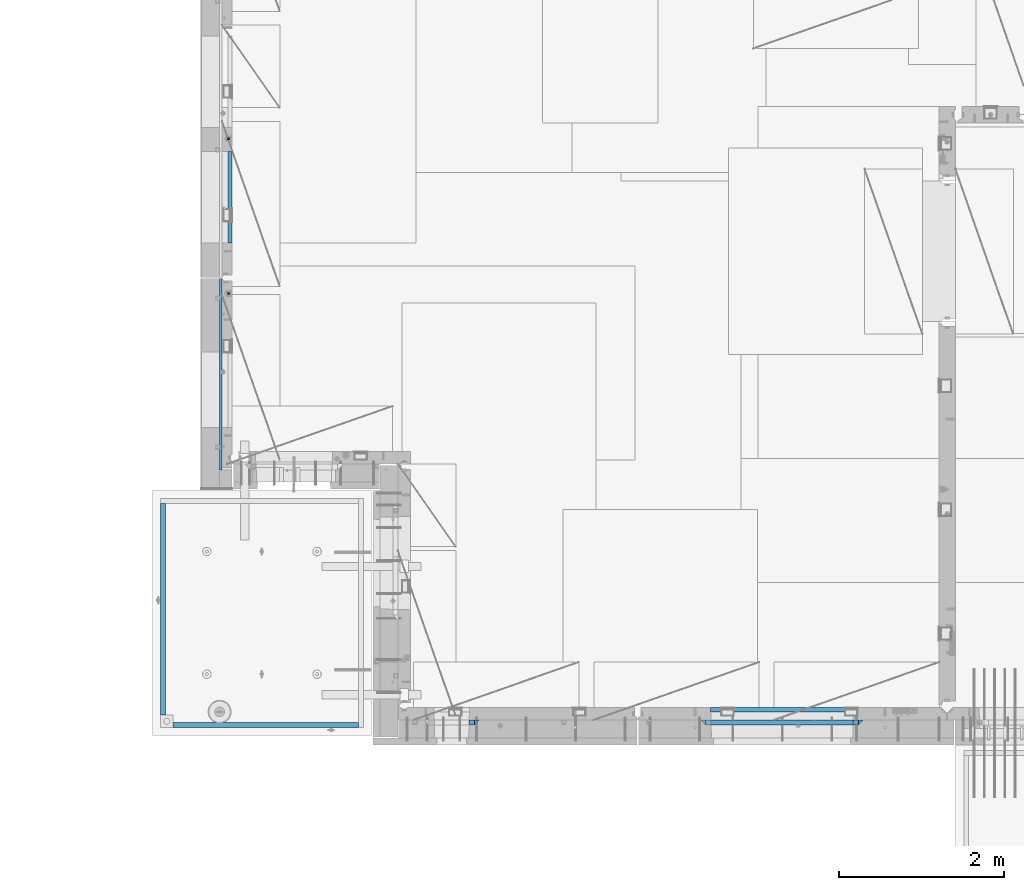
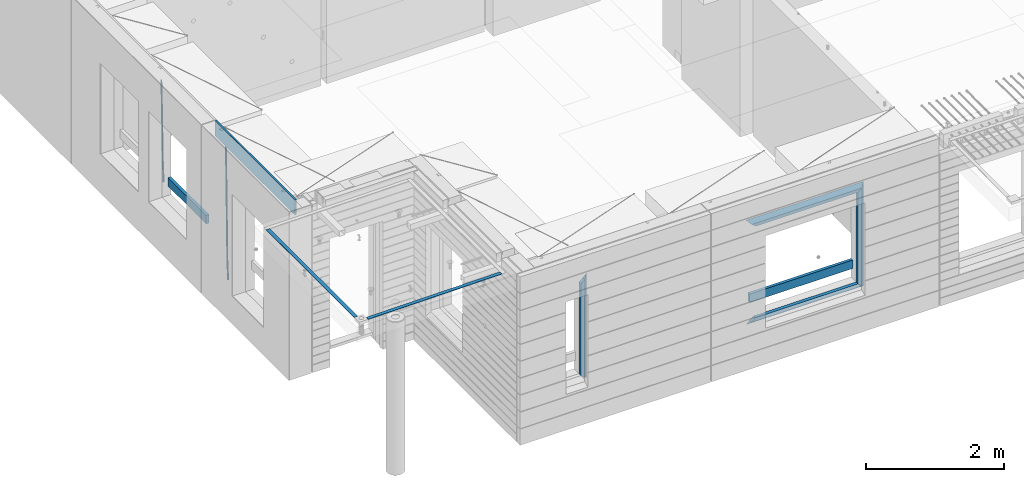
# One storey, part 87 of 341: 15 beams, 5 elements without a shape of their own.
"""IFC2X3 building model written with IfcOpenShell, lengths in millimetres."""

from ifc_helpers import new_model, si_unit, frame, origin_with_axes, place, context, subcontext, project, spatial, faceted_brep, material, type_object, element, aggregate, save


model = new_model("IFC2X3")

# Units and contexts
model_context = context("Model", 3, precision=1e-05, world=origin_with_axes())
body_context = subcontext(model_context, "Body", "Model", "MODEL_VIEW")
ifc_project = project(units=[si_unit("LENGTHUNIT", "METRE", prefix="MILLI"), si_unit("AREAUNIT", "SQUARE_METRE"), si_unit("VOLUMEUNIT", "CUBIC_METRE"), si_unit("MASSUNIT", "GRAM", prefix="KILO"), si_unit("TIMEUNIT", "SECOND"), si_unit("PLANEANGLEUNIT", "RADIAN"), si_unit("SOLIDANGLEUNIT", "STERADIAN"), si_unit("THERMODYNAMICTEMPERATUREUNIT", "DEGREE_CELSIUS"), si_unit("LUMINOUSINTENSITYUNIT", "LUMEN")], contexts=[model_context])

# Site, building, storey
site_placement = place(None, origin_with_axes())
site = spatial("IfcSite", under=ifc_project, at=site_placement, CompositionType="ELEMENT")
building_placement = place(site_placement, origin_with_axes())
building = spatial("IfcBuilding", under=site, at=building_placement, CompositionType="ELEMENT")
storey_placement = place(building_placement, origin_with_axes())
storey = spatial("IfcBuildingStorey", under=building, at=storey_placement, Name="5", CompositionType="ELEMENT", Elevation=0.0)

# Assembly, beam
assembly_1_placement = place(storey_placement, origin_with_axes())
assembly_1 = element("IfcElementAssembly", 1, at=assembly_1_placement, inside=storey, AssemblyPlace="NOTDEFINED", PredefinedType="REINFORCEMENT_UNIT")
ifc_material_1 = material()
beam_type_1 = type_object("IfcBeamType", Name="D20", PredefinedType="NOTDEFINED")
beam_1_placement = place(assembly_1_placement, frame((7964.99984877319, 14888.5021362169, 94590.0), z_axis=(-0.999642804636942, -0.000205726999925762, -0.0267249099902983), x_axis=(-0.0267249099948371, 4.30000201934385e-08, 0.999642825806181)))
beam_1 = element("IfcBeam", 2, at=beam_1_placement, type_object=beam_type_1, material=ifc_material_1, Name="JM20", ObjectType="D20", context=body_context, shape_type="Brep", body=[
    faceted_brep([(0.0, -10.0, 0.0), (-4.19531716033816e-08, -7.07106781186667, -7.07106781187031), (60.4266690400545, -7.0710677960451, -7.07106780570757), (60.4266690441291, -9.99999998418934, 6.15546014159918e-09), (0.0, 0.0, -10.0), (60.426669036824, 1.58106558956206e-08, -9.99999999384454), (4.196772351861e-08, 7.07106781186303, -7.07106781186667), (60.4266690363438, 7.07106782768096, -7.07106780570757), (0.0, 10.0, 0.0), (60.4266690388904, 10.0000000158179, 6.15182216279209e-09), (4.196772351861e-08, 7.07106781185939, 7.07106781185939), (60.4266690429649, 7.07106782768096, 7.07106781802577), (0.0, 0.0, 10.0), (60.4266690461809, 1.58179318532348e-08, 10.0000000061555), (-4.19531716033816e-08, -7.07106781187031, 7.07106781185939), (60.4266690466611, -7.07106779605238, 7.07106781802213), (61.0378400410118, -7.07106779588503, -7.07106780564936), (60.991799419251, -9.99999998403655, 6.21366780251265e-09), (61.0569027789461, 1.5985278878361e-08, -9.99999999378269), (61.0378209396877, 7.07106782784831, -7.07106780564936), (60.9917724058905, 10.0000000159635, 6.21366780251265e-09), (60.9457317841297, 7.07106782781193, 7.0710678180767), (60.9266690461809, 1.59488990902901e-08, 10.0000000062028), (60.9457508854539, -7.07106779591413, 7.0710678180767), (61.6489592143771, -7.07106614513759, -7.06310863441468), (61.5568818710308, -9.9999984576425, 0.00735959856683621), (61.6870830769039, 1.71821739058942e-06, -9.99179257185824), (61.6489210170112, 7.07106947854481, -7.06310888312146), (61.556827851804, 10.0000015422847, 0.00735924683976918), (61.4647505084577, 7.07106922979438, 7.07782747982128), (61.4266266459163, 1.36643211590126e-06, 10.0065114172685), (61.464788705809, -7.07106639389531, 7.07782772852806), (176.543135720174, -7.07075579406956, -5.56673531796696), (176.451058376813, -9.99968810657447, 1.50373291501455), (176.581259582701, 0.000312069292704109, -8.49541925541052), (176.543097522794, 7.07137982961285, -5.56673556667374), (176.451004357587, 10.00031189336, 1.50373256329476), (176.35892701424, 7.07137958085514, 8.57420079627263), (176.320803151699, 0.000311717507429421, 11.5028847337162), (176.358965211621, -7.07075604281999, 8.57420104497578), (177.098753836006, -7.07075429323595, -5.55949898843028), (176.98362511232, -9.99968666800123, 1.510669025065), (177.146421932586, 0.000313595905026887, -8.48805862247536), (177.098706077581, 7.07138133041735, -5.55949936166144), (176.983557571715, 10.0003133318824, 1.51066849724157), (176.868428848029, 7.07138095712435, 8.58083651073321), (176.820760751449, 0.000313067976094317, 11.5093961447819), (176.868476606425, -7.07075466652896, 8.58083688396073), (177.654312950661, -7.07075204110879, -5.54863964998367), (177.516135294456, -9.99968450931192, 1.52107783331303), (177.711524267797, 0.000315886711177882, -8.47701274570863), (177.654255632195, 7.07138358250813, -5.54864021007961), (177.516054233929, 10.0003154905207, 1.5210770412159), (177.377876577739, 7.0713830223176, 8.59079452451624), (177.320665260588, 0.000315094497636892, 11.5191676202448), (177.377933896176, -7.07075260129932, 8.59079508461218), (299.461778333818, -7.07025827596954, -3.16770791544877), (299.323600677439, -9.99919074416357, 3.90200956798253), (299.518989651391, 0.000809651852250681, -6.09608101123195), (299.46172101624, 7.07187734764193, -3.16770847554471), (299.323519618119, 10.0008092556727, 3.90200877589086), (299.18534196174, 7.07187678747687, 10.971726259324), (299.128130644167, 0.000808859655080596, 13.9000993551072), (299.185399279333, -7.07025883613824, 10.9717268194163), (300.005099199436, -7.07025607348805, -3.15708779472698), (299.971788958996, -9.99918809853989, 3.91467979818117), (300.018894160545, 0.00081167833377549, -6.08630953626562), (300.005085253739, 7.07187955030167, -3.15708750704471), (299.971753863239, 10.0008119014747, 3.91467990454839), (299.93844362146, 7.0718798403559, 10.9864468987271), (299.924648660366, 0.000812088532256894, 13.9156686402657), (299.938457567187, -7.07025578343564, 10.9864466110448), (300.548496018673, -7.07025720445017, -3.16258750978159), (300.620052478174, -9.9991894658433, 3.90811820064846), (300.518868553889, 0.000810637746326393, -6.09136977328126), (300.548525450897, 7.07187841925042, -3.16258766112878), (300.620094101629, 10.000810534113, 3.90811798661343), (300.69165056113, 7.07187827271991, 10.9788236970453), (300.721278025885, 0.000810430521596572, 13.907605960545), (300.691621128892, -7.07025735098068, 10.9788238483907), (1693.63216510082, -7.07315660432141, -17.2619766794614), (1693.70372156033, -10.0020888657109, -10.1912709690314), (1693.60253763606, -0.00208876212127507, -20.1907589429611), (1693.63219453306, 7.068979019381, -17.2619768308086), (1693.7037631838, 9.9979111342418, -10.1912711830664), (1693.77531964328, 7.06897887284867, -3.12056547263455), (1693.80494710806, -0.00208896934782388, -0.191783209134883), (1693.77529021105, -7.0731567508501, -3.12056532128736), (1694.29779868275, -7.07315798969103, -17.2687135518572), (1694.26743251897, -10.0020900389554, -10.1969762833342), (1694.34857500881, -0.00209031483609579, -20.1983095815103), (1694.39001741401, 7.06897744213711, -17.2696467503938), (1694.39784949942, 9.99790968965317, -10.1982960253627), (1694.36748333565, 7.06897764038877, -3.12655875683777), (1694.3167070096, -0.00209003446616407, -0.196962727188293), (1694.2752646044, -7.07315779143937, -3.125625558303), (1694.96335083364, -7.08183692566672, -17.2598557114488), (1694.83107451542, -10.0094400457037, -10.1894747662172), (1695.09452111425, -0.0118176043979474, -20.1883817771341), (1695.14774758583, 7.05909648594388, -17.259562111758), (1695.09185090323, 9.98885976961174, -10.1890595535533), (1694.95957458501, 7.0612566495729, -3.11867860832172), (1694.82840430441, -0.00876267169223865, -0.190152542638316), (1694.77517783281, -7.07967676203589, -3.11897220801256), (1716.74088258609, -7.36582038739652, -16.9700183177756), (1716.60860626785, -10.2934235074299, -9.8996373725422), (1716.87205286669, -0.295801066125932, -19.898544383459), (1716.92527933829, 6.77511302421226, -16.9697247180848), (1716.86938265568, 9.70487630788193, -9.89922215988008), (1716.73710633747, 6.77727318784673, -2.82884121464849), (1716.60593605686, -0.292746133423861, 0.0996848510367272), (1716.55270958526, -7.36366022376751, -2.82913481433934), (1717.37632925155, -7.37410674169405, -16.9615611515819), (1717.2686961548, -10.302031214369, -9.89085222946233), (1717.45037731848, -0.30334253509136, -19.8908474573927), (1717.44746400231, 6.76830362954752, -16.96277495703), (1717.36929588411, 9.6983573372836, -9.89256880959147), (1717.26166278738, 6.77043286460685, -2.82185988747187), (1717.18761472043, -0.300331341994024, 0.107426418340765), (1717.1905280366, -7.3719775066329, -2.82064608202199), (1718.0118297398, -7.37223067542982, -16.9532990407679), (1717.92884180055, -10.3000626540106, -9.8822625771154), (1718.02875100763, -0.301644694996867, -19.8833453418993), (1717.96969335481, 6.76984191386691, -16.9560200956876), (1717.86925195342, 9.69984820183527, -9.88611072988533), (1717.78626401415, 6.77201622325447, -2.81507426623284), (1717.76934274634, -0.298569757178484, 0.114972034898528), (1717.82840039914, -7.37005636604226, -2.81235321131317), (1818.03261514839, -7.07396855575644, -15.6559248891263), (1817.94962720915, -10.0018005343409, -8.58488842547376), (1818.04953641623, -0.00338257532712305, -18.5859711902594), (1817.99047876342, 7.06810403353848, -15.6586459440477), (1817.89003736203, 9.99811032150683, -8.58873657824552), (1817.80704942276, 7.07027834292421, -1.51770011459121), (1817.79012815493, -0.00030763750692131, 1.41234618654016), (1817.84918580775, -7.07179424637252, -1.51497905967153)], [[[0, 1, 2, 3]], [[1, 4, 5, 2]], [[4, 6, 7, 5]], [[6, 8, 9, 7]], [[8, 10, 11, 9]], [[10, 12, 13, 11]], [[12, 14, 15, 13]], [[14, 0, 3, 15]], [[14, 12, 10, 8, 6, 4, 1, 0]], [[3, 2, 16, 17]], [[2, 5, 18, 16]], [[5, 7, 19, 18]], [[7, 9, 20, 19]], [[9, 11, 21, 20]], [[11, 13, 22, 21]], [[13, 15, 23, 22]], [[15, 3, 17, 23]], [[17, 16, 24, 25]], [[16, 18, 26, 24]], [[18, 19, 27, 26]], [[19, 20, 28, 27]], [[20, 21, 29, 28]], [[21, 22, 30, 29]], [[22, 23, 31, 30]], [[23, 17, 25, 31]], [[25, 24, 32, 33]], [[24, 26, 34, 32]], [[26, 27, 35, 34]], [[27, 28, 36, 35]], [[28, 29, 37, 36]], [[29, 30, 38, 37]], [[30, 31, 39, 38]], [[31, 25, 33, 39]], [[33, 32, 40, 41]], [[32, 34, 42, 40]], [[34, 35, 43, 42]], [[35, 36, 44, 43]], [[36, 37, 45, 44]], [[37, 38, 46, 45]], [[38, 39, 47, 46]], [[39, 33, 41, 47]], [[41, 40, 48, 49]], [[40, 42, 50, 48]], [[42, 43, 51, 50]], [[43, 44, 52, 51]], [[44, 45, 53, 52]], [[45, 46, 54, 53]], [[46, 47, 55, 54]], [[47, 41, 49, 55]], [[49, 48, 56, 57]], [[48, 50, 58, 56]], [[50, 51, 59, 58]], [[51, 52, 60, 59]], [[52, 53, 61, 60]], [[53, 54, 62, 61]], [[54, 55, 63, 62]], [[55, 49, 57, 63]], [[57, 56, 64, 65]], [[56, 58, 66, 64]], [[58, 59, 67, 66]], [[59, 60, 68, 67]], [[60, 61, 69, 68]], [[61, 62, 70, 69]], [[62, 63, 71, 70]], [[63, 57, 65, 71]], [[65, 64, 72, 73]], [[64, 66, 74, 72]], [[66, 67, 75, 74]], [[67, 68, 76, 75]], [[68, 69, 77, 76]], [[69, 70, 78, 77]], [[70, 71, 79, 78]], [[71, 65, 73, 79]], [[73, 72, 80, 81]], [[72, 74, 82, 80]], [[74, 75, 83, 82]], [[75, 76, 84, 83]], [[76, 77, 85, 84]], [[77, 78, 86, 85]], [[78, 79, 87, 86]], [[79, 73, 81, 87]], [[81, 80, 88, 89]], [[80, 82, 90, 88]], [[82, 83, 91, 90]], [[83, 84, 92, 91]], [[84, 85, 93, 92]], [[85, 86, 94, 93]], [[86, 87, 95, 94]], [[87, 81, 89, 95]], [[89, 88, 96, 97]], [[88, 90, 98, 96]], [[90, 91, 99, 98]], [[91, 92, 100, 99]], [[92, 93, 101, 100]], [[93, 94, 102, 101]], [[94, 95, 103, 102]], [[95, 89, 97, 103]], [[97, 96, 104, 105]], [[96, 98, 106, 104]], [[98, 99, 107, 106]], [[99, 100, 108, 107]], [[100, 101, 109, 108]], [[101, 102, 110, 109]], [[102, 103, 111, 110]], [[103, 97, 105, 111]], [[105, 104, 112, 113]], [[104, 106, 114, 112]], [[106, 107, 115, 114]], [[107, 108, 116, 115]], [[108, 109, 117, 116]], [[109, 110, 118, 117]], [[110, 111, 119, 118]], [[111, 105, 113, 119]], [[113, 112, 120, 121]], [[112, 114, 122, 120]], [[114, 115, 123, 122]], [[115, 116, 124, 123]], [[116, 117, 125, 124]], [[117, 118, 126, 125]], [[118, 119, 127, 126]], [[119, 113, 121, 127]], [[121, 120, 128, 129]], [[120, 122, 130, 128]], [[122, 123, 131, 130]], [[123, 124, 132, 131]], [[124, 125, 133, 132]], [[125, 126, 134, 133]], [[126, 127, 135, 134]], [[127, 121, 129, 135]], [[130, 131, 132, 133, 134, 135, 129, 128]]]),
])

assembly_2_placement = place(storey_placement, origin_with_axes())
assembly_2 = element("IfcElementAssembly", 3, at=assembly_2_placement, inside=storey, AssemblyPlace="NOTDEFINED", PredefinedType="REINFORCEMENT_UNIT")
beam_2_placement = place(assembly_2_placement, frame((7964.99972837123, 13015.0021274634, 93990.0), z_axis=(-0.999642804636942, -0.000205726999925762, -0.0267249099902983), x_axis=(-0.0267249099948371, 4.30000201934385e-08, 0.999642825806181)))
beam_2 = element("IfcBeam", 4, at=beam_2_placement, type_object=beam_type_1, material=ifc_material_1, Name="JM20", ObjectType="D20", context=body_context, shape_type="Brep", body=[
    faceted_brep([(0.0, -10.0, 0.0), (-4.19531716033816e-08, -7.07106781186667, -7.07106781187031), (60.4266690400545, -7.0710677960451, -7.07106780570757), (60.4266690441291, -9.99999998418934, 6.15546014159918e-09), (0.0, 0.0, -10.0), (60.426669036824, 1.58106558956206e-08, -9.99999999384454), (4.196772351861e-08, 7.07106781186303, -7.07106781186667), (60.4266690363438, 7.07106782768096, -7.07106780570757), (0.0, 10.0, 0.0), (60.4266690388904, 10.0000000158179, 6.15182216279209e-09), (4.196772351861e-08, 7.07106781185939, 7.07106781185939), (60.4266690429649, 7.07106782768096, 7.07106781802577), (0.0, 0.0, 10.0), (60.4266690461809, 1.58179318532348e-08, 10.0000000061555), (-4.19531716033816e-08, -7.07106781187031, 7.07106781185939), (60.4266690466611, -7.07106779605238, 7.07106781802213), (61.0378400410118, -7.07106779588503, -7.07106780564936), (60.991799419251, -9.99999998403655, 6.21366780251265e-09), (61.0569027789461, 1.5985278878361e-08, -9.99999999378269), (61.0378209396877, 7.07106782784831, -7.07106780564936), (60.9917724058905, 10.0000000159635, 6.21366780251265e-09), (60.9457317841297, 7.07106782781193, 7.0710678180767), (60.9266690461809, 1.59488990902901e-08, 10.0000000062028), (60.9457508854539, -7.07106779591413, 7.0710678180767), (61.6489592143771, -7.07106614513759, -7.06310863441468), (61.5568818710308, -9.9999984576425, 0.00735959856683621), (61.6870830769039, 1.71821739058942e-06, -9.99179257185824), (61.6489210170112, 7.07106947854481, -7.06310888312146), (61.556827851804, 10.0000015422847, 0.00735924683976918), (61.4647505084577, 7.07106922979438, 7.07782747982128), (61.4266266459163, 1.36643211590126e-06, 10.0065114172685), (61.464788705809, -7.07106639389531, 7.07782772852806), (176.543135720174, -7.07075579406956, -5.56673531796696), (176.451058376813, -9.99968810657447, 1.50373291501455), (176.581259582701, 0.000312069292704109, -8.49541925541052), (176.543097522794, 7.07137982961285, -5.56673556667374), (176.451004357587, 10.00031189336, 1.50373256329476), (176.35892701424, 7.07137958085514, 8.57420079627263), (176.320803151699, 0.000311717507429421, 11.5028847337162), (176.358965211621, -7.07075604281999, 8.57420104497578), (177.098753836006, -7.07075429323595, -5.55949898843028), (176.98362511232, -9.99968666800123, 1.510669025065), (177.146421932586, 0.000313595905026887, -8.48805862247536), (177.098706077581, 7.07138133041735, -5.55949936166144), (176.983557571715, 10.0003133318824, 1.51066849724157), (176.868428848029, 7.07138095712435, 8.58083651073321), (176.820760751449, 0.000313067976094317, 11.5093961447819), (176.868476606425, -7.07075466652896, 8.58083688396073), (177.654312950661, -7.07075204110879, -5.54863964998367), (177.516135294456, -9.99968450931192, 1.52107783331303), (177.711524267797, 0.000315886711177882, -8.47701274570863), (177.654255632195, 7.07138358250813, -5.54864021007961), (177.516054233929, 10.0003154905207, 1.5210770412159), (177.377876577739, 7.0713830223176, 8.59079452451624), (177.320665260588, 0.000315094497636892, 11.5191676202448), (177.377933896176, -7.07075260129932, 8.59079508461218), (299.436796249574, -7.07025836271714, -3.1681962331204), (299.298618593355, -9.99919083092027, 3.90152125031091), (299.494007566798, 0.000809565110102994, -6.09656932889993), (299.436738931283, 7.07187726089978, -3.16819679320906), (299.298537533061, 10.0008091689197, 3.90152045822106), (299.160359876842, 7.07187670072017, 10.9712379416487), (299.103148559603, 0.000808772889286047, 13.8996110374392), (299.160417195119, -7.07025892290039, 10.9712385017483), (299.98743051647, -7.07025613056248, -3.15743315966392), (299.971788958996, -9.99918809853989, 3.91467979818117), (299.993912075952, 0.000811591617093654, -6.08679785393178), (299.987423933868, 7.07187949325817, -3.1574327280432), (299.971753863239, 10.0008119014747, 3.91467990454839), (299.95611230444, 7.07187992653053, 10.9867922621015), (299.949630744944, 0.000812204350950196, 13.9161569563694), (299.956118887014, -7.07025569729012, 10.9867918304735), (300.538107039494, -7.07025785017686, -3.16575821840888), (300.644985195438, -9.99919020432935, 3.90450175465594), (300.493854948218, 0.000810030429420294, -6.09435592770024), (300.538151196495, 7.071877773491, -3.16575855385963), (300.645047642858, 10.0008097955724, 3.90450128024895), (300.751925798773, 7.07187744142357, 10.9747612533101), (300.796177890064, 0.000809560813650023, 13.9033589625978), (300.751881641787, -7.07025818224065, 10.9747615887682), (2293.36490490142, -7.07648090940347, -33.2930642912361), (2293.47178305736, -10.0054132635523, -26.2228043181785), (2293.32065281013, -0.00541302880083094, -36.2216620005347), (2293.36494905842, 7.06565471425711, -33.2930646266868), (2293.47184550477, 9.99458673634581, -26.2228047925819), (2293.57872366071, 7.06565438219332, -19.1525448195243), (2293.62297575199, -0.00541349841296324, -16.2239471102366), (2293.57867950371, -7.0764812414709, -19.1525444840736), (2294.0658245362, -7.07648309818615, -33.3036607065333), (2294.05312277409, -10.0054150789219, -26.2315929392535), (2294.10928714235, -0.00541549149056664, -36.2335844756526), (2294.15805078732, 7.06565223761572, -33.3050546393533), (2294.18355038921, 9.99458451388637, -26.2335642579346), (2294.17084862708, 7.06565253314329, -19.1614964906439), (2294.12738602093, -0.00541507354500936, -16.2315727215355), (2294.07862237596, -7.07648280265857, -19.1601025578348), (2294.76670261032, -7.08562269121467, -33.294332712383), (2294.63442802057, -10.0129954178956, -26.2238563411993), (2294.89787471293, -0.0156988342423574, -36.2230891548279), (2294.95110548967, 7.05531064255774, -33.2944998654275), (2294.89521307347, 9.98530428734011, -26.2240927312887), (2294.76293848372, 7.0579315606592, -19.1536163601049), (2294.63176638114, -0.0119922963167483, -16.2248599176673), (2294.57853560438, -7.08300177311321, -19.1534492070678), (2316.52657204497, -7.36937582653991, -33.0047303660212), (2316.39429745522, -10.2967485532172, -25.9342539948302), (2316.65774414754, -0.299451969567599, -35.9334868084661), (2316.7109749243, 6.7715575072325, -33.0048975190657), (2316.65508250811, 9.70155115201487, -25.9344903849269), (2316.52280791836, 6.7741784253376, -18.8640140137468), (2316.39163581574, -0.295745431634714, -15.9352575713092), (2316.33840503903, -7.36675490843481, -18.863846860706), (2317.16202064224, -7.37766220584308, -32.9962731735213), (2317.05438744847, -10.3053562613532, -25.9254688497131), (2317.23607125619, -0.306993473008333, -35.925789846493), (2317.23316144495, 6.76474808850253, -32.9979477328052), (2317.15499573652, 9.6950321815566, -25.9278370341635), (2317.04736254275, 6.7673381260538, -18.8570327103698), (2316.97331192881, -0.303330606784584, -15.9275160373909), (2316.97622174003, -7.37507216829545, -18.8553581510787), (2317.79752306276, -7.37578610372293, -32.9880110666527), (2317.71453320107, -10.3033876998124, -25.9168792378296), (2317.81444760226, -0.305295583297266, -35.918287695793), (2317.75539265381, 6.76628640723357, -32.9911928173897), (2317.65495180529, 9.69652304524061, -25.9213789128698), (2317.5719619436, 6.76892144914746, -18.8502470840467), (2317.55503740412, -0.301569071270933, -15.9199704549137), (2317.61409235255, -7.3731510618054, -18.847065333317), (2417.8183084176, -7.07752398473531, -31.6906369377139), (2417.73531855589, -10.0051255808248, -24.6195051088798), (2417.83523295709, -0.007033464313281, -34.6209135668432), (2417.77617800863, 7.06454852621755, -31.6938186884508), (2417.67573716014, 9.99478516423187, -24.6240047839383), (2417.59274729842, 7.06718356813872, -17.5528729551006), (2417.57582275895, -0.00330695228694822, -14.6225963259749), (2417.6348777074, -7.07488894281778, -17.5496912043673)], [[[0, 1, 2, 3]], [[1, 4, 5, 2]], [[4, 6, 7, 5]], [[6, 8, 9, 7]], [[8, 10, 11, 9]], [[10, 12, 13, 11]], [[12, 14, 15, 13]], [[14, 0, 3, 15]], [[14, 12, 10, 8, 6, 4, 1, 0]], [[3, 2, 16, 17]], [[2, 5, 18, 16]], [[5, 7, 19, 18]], [[7, 9, 20, 19]], [[9, 11, 21, 20]], [[11, 13, 22, 21]], [[13, 15, 23, 22]], [[15, 3, 17, 23]], [[17, 16, 24, 25]], [[16, 18, 26, 24]], [[18, 19, 27, 26]], [[19, 20, 28, 27]], [[20, 21, 29, 28]], [[21, 22, 30, 29]], [[22, 23, 31, 30]], [[23, 17, 25, 31]], [[25, 24, 32, 33]], [[24, 26, 34, 32]], [[26, 27, 35, 34]], [[27, 28, 36, 35]], [[28, 29, 37, 36]], [[29, 30, 38, 37]], [[30, 31, 39, 38]], [[31, 25, 33, 39]], [[33, 32, 40, 41]], [[32, 34, 42, 40]], [[34, 35, 43, 42]], [[35, 36, 44, 43]], [[36, 37, 45, 44]], [[37, 38, 46, 45]], [[38, 39, 47, 46]], [[39, 33, 41, 47]], [[41, 40, 48, 49]], [[40, 42, 50, 48]], [[42, 43, 51, 50]], [[43, 44, 52, 51]], [[44, 45, 53, 52]], [[45, 46, 54, 53]], [[46, 47, 55, 54]], [[47, 41, 49, 55]], [[49, 48, 56, 57]], [[48, 50, 58, 56]], [[50, 51, 59, 58]], [[51, 52, 60, 59]], [[52, 53, 61, 60]], [[53, 54, 62, 61]], [[54, 55, 63, 62]], [[55, 49, 57, 63]], [[57, 56, 64, 65]], [[56, 58, 66, 64]], [[58, 59, 67, 66]], [[59, 60, 68, 67]], [[60, 61, 69, 68]], [[61, 62, 70, 69]], [[62, 63, 71, 70]], [[63, 57, 65, 71]], [[65, 64, 72, 73]], [[64, 66, 74, 72]], [[66, 67, 75, 74]], [[67, 68, 76, 75]], [[68, 69, 77, 76]], [[69, 70, 78, 77]], [[70, 71, 79, 78]], [[71, 65, 73, 79]], [[73, 72, 80, 81]], [[72, 74, 82, 80]], [[74, 75, 83, 82]], [[75, 76, 84, 83]], [[76, 77, 85, 84]], [[77, 78, 86, 85]], [[78, 79, 87, 86]], [[79, 73, 81, 87]], [[81, 80, 88, 89]], [[80, 82, 90, 88]], [[82, 83, 91, 90]], [[83, 84, 92, 91]], [[84, 85, 93, 92]], [[85, 86, 94, 93]], [[86, 87, 95, 94]], [[87, 81, 89, 95]], [[89, 88, 96, 97]], [[88, 90, 98, 96]], [[90, 91, 99, 98]], [[91, 92, 100, 99]], [[92, 93, 101, 100]], [[93, 94, 102, 101]], [[94, 95, 103, 102]], [[95, 89, 97, 103]], [[97, 96, 104, 105]], [[96, 98, 106, 104]], [[98, 99, 107, 106]], [[99, 100, 108, 107]], [[100, 101, 109, 108]], [[101, 102, 110, 109]], [[102, 103, 111, 110]], [[103, 97, 105, 111]], [[105, 104, 112, 113]], [[104, 106, 114, 112]], [[106, 107, 115, 114]], [[107, 108, 116, 115]], [[108, 109, 117, 116]], [[109, 110, 118, 117]], [[110, 111, 119, 118]], [[111, 105, 113, 119]], [[113, 112, 120, 121]], [[112, 114, 122, 120]], [[114, 115, 123, 122]], [[115, 116, 124, 123]], [[116, 117, 125, 124]], [[117, 118, 126, 125]], [[118, 119, 127, 126]], [[119, 113, 121, 127]], [[121, 120, 128, 129]], [[120, 122, 130, 128]], [[122, 123, 131, 130]], [[123, 124, 132, 131]], [[124, 125, 133, 132]], [[125, 126, 134, 133]], [[126, 127, 135, 134]], [[127, 121, 129, 135]], [[130, 131, 132, 133, 134, 135, 129, 128]]]),
])

assembly_3_placement = place(storey_placement, origin_with_axes())
assembly_3 = element("IfcElementAssembly", 5, at=assembly_3_placement, inside=storey, AssemblyPlace="NOTDEFINED", PredefinedType="REINFORCEMENT_UNIT")
ifc_material_2 = material(Name="TIMBER/T24")
beam_type_2 = type_object("IfcBeamType", PredefinedType="NOTDEFINED")
beam_3_placement = place(assembly_3_placement, frame((13795.0009023501, 7974.99972412935, 94685.0), z_axis=(0.0, 0.0, 1.0), x_axis=(1.0, 0.0, 0.0)))
beam_3 = element("IfcBeam", 6, at=beam_3_placement, type_object=beam_type_2, material=ifc_material_2, context=body_context, shape_type="Brep", body=[
    faceted_brep([(-3.63797880709171e-12, 24.9999999999964, -75.0), (-3.63797880709171e-12, 24.9999999999964, 75.0), (1730.0, 25.0, 75.0), (1730.0, 25.0, -75.0), (0.0, -25.0000000000073, 75.0), (1730.0, -25.0, 75.0), (0.0, -25.0000000000073, -75.0), (1730.0, -25.0, -75.0)], [[[0, 1, 2, 3]], [[1, 4, 5, 2]], [[4, 6, 7, 5]], [[6, 0, 3, 7]], [[5, 7, 3, 2]], [[6, 4, 1, 0]]]),
])

# Beam
beam_4_placement = place(assembly_1_placement, frame((7975.00000026382, 14735.0004107749, 94685.0), z_axis=(0.0, 0.0, 1.0), x_axis=(0.0, -1.0, 0.0)))
beam_4 = element("IfcBeam", 7, at=beam_4_placement, type_object=beam_type_2, material=ifc_material_2, context=body_context, shape_type="Brep", body=[
    faceted_brep([(-3.63797880709171e-12, 24.9999999999964, -75.0), (-3.63797880709171e-12, 24.9999999999964, 75.0), (1110.0, 24.9999999999964, 75.0), (1110.0, 24.9999999999964, -75.0), (0.0, -25.0000000000073, 75.0), (1110.0, -25.0000000000073, 75.0), (0.0, -25.0000000000073, -75.0), (1110.0, -25.0000000000073, -75.0)], [[[0, 1, 2, 3]], [[1, 4, 5, 2]], [[4, 6, 7, 5]], [[6, 0, 3, 7]], [[5, 7, 3, 2]], [[6, 4, 1, 0]]]),
])

aggregate(assembly_1, [beam_1, beam_4])

# Assembly, beams
assembly_4_placement = place(storey_placement, origin_with_axes())
assembly_4 = element("IfcElementAssembly", 8, at=assembly_4_placement, inside=storey, AssemblyPlace="NOTDEFINED", PredefinedType="REINFORCEMENT_UNIT")
ifc_material_3 = material(Name="CONCRETE/Concrete_Undefined")
beam_type_3 = type_object("IfcBeamType", PredefinedType="NOTDEFINED")
beam_5_placement = place(assembly_4_placement, frame((7164.89422591706, 10470.0076633258, 96701.6030105556), z_axis=(0.0, -1.17599999975856e-06, 0.999999999999309), x_axis=(4.13430000058061e-05, -0.999999999144687, -1.176000002514e-06)))
beam_5 = element("IfcBeam", 9, at=beam_5_placement, type_object=beam_type_3, material=ifc_material_3, context=body_context, shape_type="Brep", body=[
    faceted_brep([(2.5465851649642e-11, 29.9999999999982, -4.99999999998545), (-2.91038304567337e-11, 29.9999999999982, 5.0), (2560.00574992944, 30.0000000000009, 5.00000000001455), (2560.00574992944, 30.0, -5.0), (-2.5465851649642e-11, -30.0000000000018, 5.0), (2560.00574992944, -29.9999999999991, 5.00000000001455), (2.72848410531878e-11, -30.0000000000018, -4.99999999998545), (2560.00574992944, -30.0, -5.0)], [[[0, 1, 2, 3]], [[1, 4, 5, 2]], [[4, 6, 7, 5]], [[6, 0, 3, 7]], [[5, 7, 3, 2]], [[6, 4, 1, 0]]]),
])
beam_6_placement = place(assembly_4_placement, frame((9529.67128970205, 7789.99860988154, 96725.2790473986), z_axis=(-0.00918361699724776, 4.9999998721906e-09, 0.999957829700257), x_axis=(-0.999957829700102, 5.55999999934641e-07, -0.00918361699724765)))
beam_6 = element("IfcBeam", 10, at=beam_6_placement, type_object=beam_type_3, material=ifc_material_3, context=body_context, shape_type="Brep", body=[
    faceted_brep([(2.5465851649642e-11, 29.9999999999982, -4.99999999998545), (-2.91038304567337e-11, 29.9999999999982, 5.0), (2244.79868782777, 30.0, 5.00000000001455), (2244.79868782778, 30.0, -4.99999999995634), (-2.5465851649642e-11, -30.0000000000018, 5.0), (2244.79868782778, -30.0000000000009, 5.00000000001455), (2.72848410531878e-11, -30.0000000000018, -4.99999999998545), (2244.79868782778, -30.0, -4.9999999999709)], [[[0, 1, 2, 3]], [[1, 4, 5, 2]], [[4, 6, 7, 5]], [[6, 0, 3, 7]], [[5, 7, 3, 2]], [[6, 4, 1, 0]]]),
])
aggregate(assembly_4, [beam_5, beam_6])

# Assembly, beam
assembly_5_placement = place(storey_placement, origin_with_axes())
assembly_5 = element("IfcElementAssembly", 11, at=assembly_5_placement, inside=storey, AssemblyPlace="NOTDEFINED", PredefinedType="REINFORCEMENT_UNIT")
ifc_material_4 = material(Name="CONCRETE/C25/30")
beam_type_4 = type_object("IfcBeamType", PredefinedType="NOTDEFINED")
beam_7_placement = place(assembly_5_placement, frame((10964.9994055559, 7820.0, 96175.0), z_axis=(-1.0, 3.00000001838171e-08, 0.0), x_axis=(0.0, 0.0, -1.0)))
beam_7 = element("IfcBeam", 12, at=beam_7_placement, type_object=beam_type_4, material=ifc_material_4, Name="SK", context=body_context, shape_type="Brep", body=[
    faceted_brep([(60.0000000000073, 30.0, 30.0), (0.0, -30.0, -30.0), (60.0000000000073, -30.0, 30.0), (1855.0, -30.0, -30.0), (1795.00000000001, -30.0, 30.0), (1795.00000000001, 30.0, 30.0)], [[[0, 1, 2]], [[3, 4, 2, 1]], [[4, 5, 0, 2]], [[5, 3, 1, 0]], [[4, 3, 5]]]),
])

# Beam
beam_8_placement = place(assembly_3_placement, frame((13675.0004364773, 7820.0, 96145.0), z_axis=(0.0, 0.0, -1.0), x_axis=(1.0, 0.0, 0.0)))
beam_8 = element("IfcBeam", 13, at=beam_8_placement, type_object=beam_type_4, material=ifc_material_4, Name="SK", context=body_context, shape_type="Brep", body=[
    faceted_brep([(60.0000000000073, 30.0, 30.0), (0.0, -30.0, -30.0), (60.0000000000073, -30.0, 30.0), (1969.99980926514, -30.0, -30.0), (1909.99980926512, -30.0, 30.0), (1909.99980926512, 30.0, 30.0)], [[[0, 1, 2]], [[2, 1, 3, 4]], [[0, 2, 4, 5]], [[1, 0, 5, 3]], [[4, 3, 5]]]),
])

beam_9_placement = place(assembly_3_placement, frame((13735.0004364773, 7820.0, 96085.0), z_axis=(0.0, 0.0, -1.0), x_axis=(1.0, 0.0, 0.0)))
beam_9 = element("IfcBeam", 14, at=beam_9_placement, type_object=beam_type_4, material=ifc_material_4, Name="SK", context=body_context, shape_type="Brep", body=[
    faceted_brep([(1785.94575521108, -30.0, 24.0540540540533), (1784.32413358946, 30.0, 25.6756756756804), (65.6754849408117, 30.0, 25.6756756756804), (64.05386331919, -30.0, 24.0540540540533), (65.6754849408117, 30.0, 26.2932727940788), (64.05386331919, -30.0, 24.9033114044141), (0.0, -30.0, -30.0), (0.0, 30.0, -30.0), (1849.99980926514, -30.0, -30.0), (1785.94575521108, -30.0, 24.9034748914273), (1784.32413358946, 30.0, 26.293436281092), (1849.99980926514, 30.0, -30.0)], [[[0, 1, 2, 3]], [[3, 2, 4, 5]], [[6, 5, 4, 7]], [[0, 3, 5, 6, 8, 9]], [[1, 0, 9, 10]], [[7, 4, 2, 1, 10, 11]], [[6, 7, 11, 8]], [[10, 9, 8, 11]]]),
])

beam_10_placement = place(assembly_3_placement, frame((15615.0002457424, 7820.0, 96175.0), z_axis=(-1.0, 3.00000001838171e-08, 0.0), x_axis=(0.0, 0.0, -1.0)))
beam_10 = element("IfcBeam", 15, at=beam_10_placement, type_object=beam_type_4, material=ifc_material_4, Name="SK", context=body_context, shape_type="Brep", body=[
    faceted_brep([(60.0000000000073, 30.0, 30.0), (0.0, -30.0, -30.0), (60.0000000000073, -30.0, 30.0), (1855.0, -30.0, -30.0), (1795.00000000001, -30.0, 30.0), (1795.00000000001, 30.0, 30.0)], [[[0, 1, 2]], [[3, 4, 2, 1]], [[4, 5, 0, 2]], [[5, 3, 1, 0]], [[4, 3, 5]]]),
])

beam_11_placement = place(assembly_3_placement, frame((15645.0002457424, 7820.0, 94350.0), z_axis=(0.0, 0.0, 1.0), x_axis=(-1.0, 3.00000001838171e-08, 0.0)))
beam_11 = element("IfcBeam", 16, at=beam_11_placement, type_object=beam_type_4, material=ifc_material_4, Name="SK", context=body_context, shape_type="Brep", body=[
    faceted_brep([(1909.99980926512, -30.0, 30.0), (1969.99980926514, -30.0, -30.0), (1909.99980926512, 30.0, 30.0), (0.0, -30.0, -30.0), (60.0000000000073, 30.0, 30.0), (60.0000000000073, -30.0, 30.0)], [[[0, 1, 2]], [[3, 4, 2, 1]], [[4, 5, 0, 2]], [[5, 3, 1, 0]], [[4, 3, 5]]]),
])

beam_12_placement = place(assembly_3_placement, frame((15585.0002457424, 7820.0, 94410.0), z_axis=(0.0, 0.0, 1.0), x_axis=(-1.0, 3.00000001838171e-08, 0.0)))
beam_12 = element("IfcBeam", 17, at=beam_12_placement, type_object=beam_type_4, material=ifc_material_4, Name="SK", context=body_context, shape_type="Brep", body=[
    faceted_brep([(1785.94594594595, -30.0, 24.0540540540533), (1784.32432432433, 30.0, 25.6756756756804), (65.6756756756768, 30.0, 25.6756756756804), (64.0540540540533, -30.0, 24.0540540540533), (1785.94594594595, -30.0, 24.9033114043996), (1784.32432432433, 30.0, 26.2932727940788), (1849.99980926514, -30.0, -30.0), (1849.99980926514, 30.0, -30.0), (0.0, -30.0, -30.0), (0.0, 30.0, -30.0), (65.6756756756768, 30.0, 26.293436281092), (64.0540540540533, -30.0, 24.9034748914419)], [[[0, 1, 2, 3]], [[1, 0, 4, 5]], [[6, 7, 5, 4]], [[8, 9, 7, 6]], [[2, 1, 5, 7, 9, 10]], [[3, 2, 10, 11]], [[6, 4, 0, 3, 11, 8]], [[8, 11, 10, 9]]]),
])

beam_type_5 = type_object("IfcBeamType", PredefinedType="NOTDEFINED")
beam_13_placement = place(assembly_5_placement, frame((10899.9994055559, 7820.0, 96115.0), z_axis=(-1.0, 3.00000001838171e-08, 0.0), x_axis=(0.0, 0.0, -1.0)))
beam_13 = element("IfcBeam", 18, at=beam_13_placement, type_object=beam_type_5, material=ifc_material_4, Name="SK", context=body_context, shape_type="Brep", body=[
    faceted_brep([(0.0, -30.0, -35.0), (54.9034748914273, -30.0, 29.0540540540533), (56.2934362811066, 30.0, 30.6756756756768), (0.0, 30.0, -35.0), (1735.0, -30.0, -35.0), (1680.09652510857, -30.0, 29.0540540540533), (1678.70656371891, 30.0, 30.6756756756768), (1735.0, 30.0, -35.0)], [[[0, 1, 2, 3]], [[1, 0, 4, 5]], [[2, 1, 5, 6]], [[3, 2, 6, 7]], [[7, 4, 0, 3]], [[4, 7, 6, 5]]]),
])

aggregate(assembly_5, [beam_7, beam_13])

beam_14_placement = place(assembly_3_placement, frame((15550.0002457424, 7820.0, 96115.0), z_axis=(-1.0, 3.00000001838171e-08, 0.0), x_axis=(0.0, 0.0, -1.0)))
beam_14 = element("IfcBeam", 19, at=beam_14_placement, type_object=beam_type_5, material=ifc_material_4, Name="SK", context=body_context, shape_type="Brep", body=[
    faceted_brep([(0.0, -30.0, -35.0), (54.9034748914273, -30.0, 29.0540540540533), (56.2934362811066, 30.0, 30.6756756756768), (0.0, 30.0, -35.0), (1735.0, -30.0, -35.0), (1680.09652510857, -30.0, 29.0540540540533), (1678.70656371891, 30.0, 30.6756756756768), (1735.0, 30.0, -35.0)], [[[0, 1, 2, 3]], [[1, 0, 4, 5]], [[2, 1, 5, 6]], [[3, 2, 6, 7]], [[7, 4, 0, 3]], [[4, 7, 6, 5]]]),
])

aggregate(assembly_3, [beam_8, beam_9, beam_10, beam_14, beam_11, beam_12, beam_3])

beam_type_6 = type_object("IfcBeamType", Name="270X30", PredefinedType="NOTDEFINED")
beam_15_placement = place(assembly_2_placement, frame((7864.99972556029, 13195.0003943318, 96605.0), z_axis=(0.0, 0.0, 1.0), x_axis=(0.0, -1.0, 0.0)))
beam_15 = element("IfcBeam", 20, at=beam_15_placement, type_object=beam_type_6, material=ifc_material_4, ObjectType="270X30", context=body_context, shape_type="Brep", body=[
    faceted_brep([(0.0, 15.0, -135.0), (0.0, 15.0, 135.0), (2320.00069431986, 15.0000000000009, 135.0), (2320.00069431986, 15.0000000000009, -135.0), (0.0, -15.0, 135.0), (2320.00069431986, -14.9999999999991, 135.0), (0.0, -15.0, -135.0), (2320.00069431986, -14.9999999999991, -135.0)], [[[0, 1, 2, 3]], [[1, 4, 5, 2]], [[4, 6, 7, 5]], [[6, 0, 3, 7]], [[5, 7, 3, 2]], [[6, 4, 1, 0]]]),
])

aggregate(assembly_2, [beam_2, beam_15])

save(model, "model.ifc")
